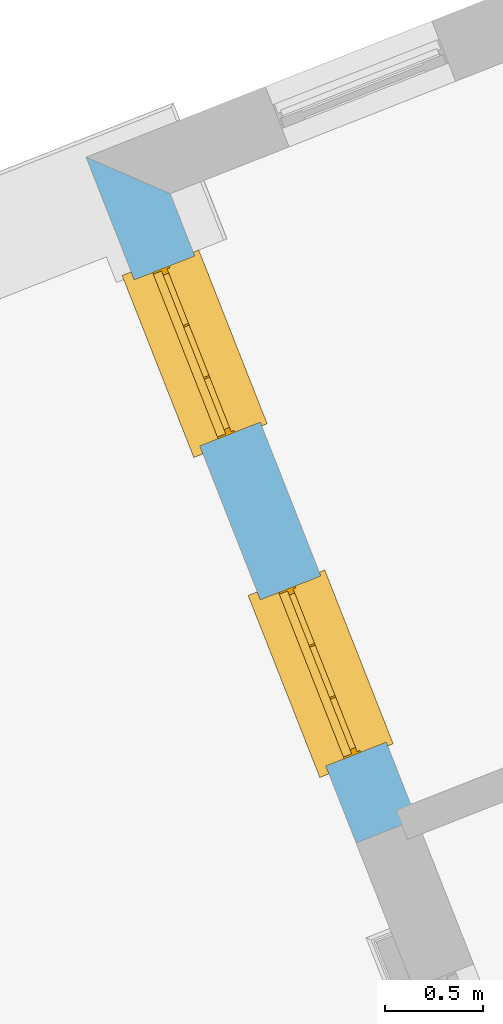
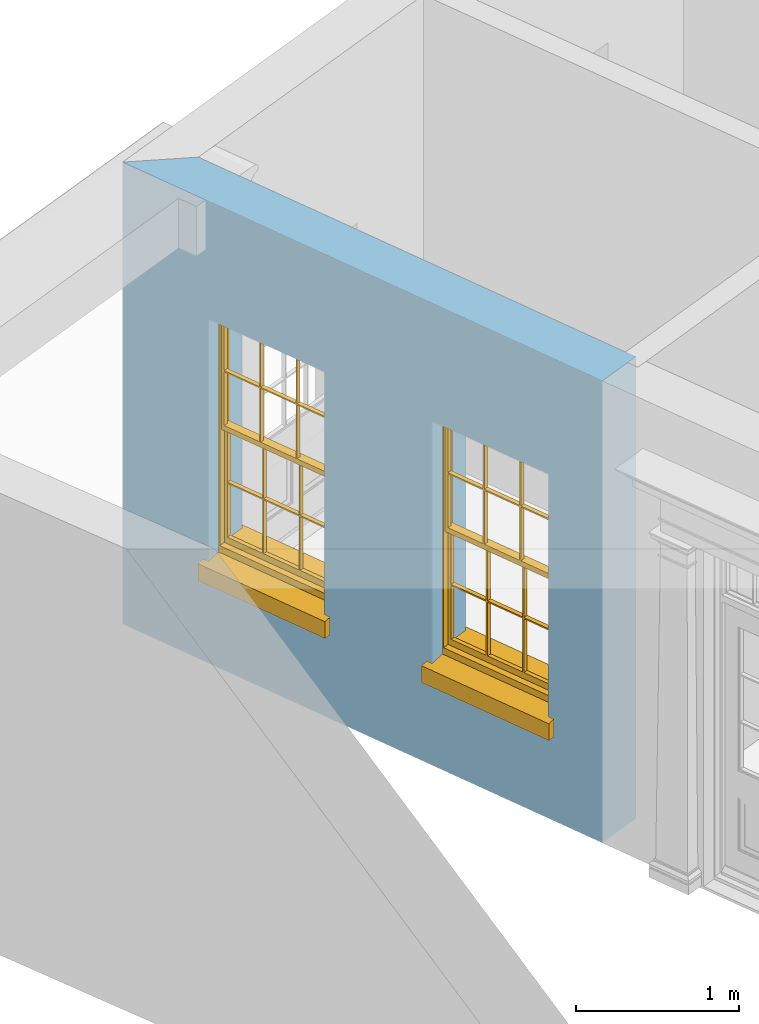
# One storey, part 3 of 8: 2 windows, 2 openings, plus 1 element that does not belong to this part.
"""IFC2X3 building model written with IfcOpenShell, lengths in metres."""

from ifc_helpers import new_model, si_unit, frame, origin, place, context, subcontext, project, spatial, polyline, outline, extrude, faceted_brep, material, layer, layer_set, layer_usage, element, fill, save


model = new_model("IFC2X3")

# Units and contexts
model_context = context("Model", 3, world=origin())
body_context = subcontext(model_context, "Body", "Model", "MODEL_VIEW")
ifc_project = project(units=[si_unit("PLANEANGLEUNIT", "RADIAN"), si_unit("MASSUNIT", "GRAM", prefix="KILO"), si_unit("FORCEUNIT", "NEWTON", prefix="KILO"), si_unit("LENGTHUNIT", "METRE")], contexts=[model_context])

# Site, building, storey
site_placement = place(None, origin())
site = spatial("IfcSite", under=ifc_project, at=site_placement, CompositionType="ELEMENT")
building_placement = place(None, origin())
building = spatial("IfcBuilding", under=site, at=building_placement, Name="Building plot-4", CompositionType="ELEMENT")
storey_placement = place(None, frame((0.0, 0.0, 3.0)))
storey = spatial("IfcBuildingStorey", under=building, at=storey_placement, Name="Floor 0", CompositionType="ELEMENT", Elevation=3.0)

# Wall, openings, windows
ifc_material = material(Name="Masonry")
ifc_layer = layer(ifc_material, 0.33, ventilated=False)
ifc_layer_set = layer_set([ifc_layer], Name="My Wall")
ifc_layer_usage = layer_usage(ifc_layer_set, "AXIS2", "NEGATIVE", 0.08)
wall_placement = place(storey_placement, origin())
wall = element("IfcWallStandardCase", 1, at=wall_placement, inside=storey, material=ifc_layer_usage, Name="exterior", context=body_context, shape_type="SweptSolid", body=[
    extrude(outline(polyline([(47.5268442142849, 51.9971616921577), (47.0988755747214, 52.1832875730829), (48.4726663727611, 48.69491601247), (48.7797136330055, 48.8158373917891), (47.5268442142849, 51.9971616921577)])), origin(), (0.0, 0.0, 1.0), 3.45),
])
opening_1_placement = place(storey_placement, frame((0.0, 0.0, 0.75)))
opening_1 = element("IfcOpeningElement", 2, at=opening_1_placement, cuts=wall, Name="Opening", ObjectType="Opening", context=body_context, shape_type="SweptSolid", body=[
    extrude(outline(polyline([(47.3443036712984, 51.5600890529762), (47.6777535354815, 50.7133829716963), (47.9848007957258, 50.8343043510155), (47.6513509315428, 51.6810104322953), (47.3443036712984, 51.5600890529762)])), origin(), (0.0, 0.0, 1.0), 1.82),
])
opening_2_placement = place(storey_placement, frame((0.0, 0.0, 0.75)))
opening_2 = element("IfcOpeningElement", 3, at=opening_2_placement, cuts=wall, Name="Opening", ObjectType="Opening", context=body_context, shape_type="SweptSolid", body=[
    extrude(outline(polyline([(47.9853955175459, 49.9322090530653), (48.3188453817289, 49.0855029717855), (48.6258926419733, 49.2064243511046), (48.2924427777902, 50.0531304323845), (47.9853955175459, 49.9322090530653)])), origin(), (0.0, 0.0, 1.0), 1.82),
])
window_1_placement = place(storey_placement, frame((47.5769152320896, 51.651696158521, 0.75), z_axis=(0.0, 0.0, 1.0), x_axis=(0.333449864183095, -0.846706081279848, 0.0)))
window_1 = element("IfcWindow", 4, at=window_1_placement, inside=storey, Name="toilet outside window", OverallHeight=1.82, OverallWidth=0.91, context=body_context, shape_type="Brep", held_by="IfcProductRepresentation", body=[
    faceted_brep([(0.033125, -0.105, 0.975209), (0.01, -0.105, 0.975209), (0.033125, -0.105, 1.376042), (0.876875, -0.105, 0.975209), (0.876875, -0.105, 1.376042), (0.9, -0.105, 0.975209), (0.876875, -0.105, 1.386042), (0.876875, -0.105, 1.786875), (0.9, -0.105, 1.81), (0.033125, -0.105, 1.786875), (0.033125, -0.105, 1.386042), (0.01, -0.105, 1.81), (0.876875, -0.135, 1.376042), (0.876875, -0.135, 0.975209), (0.9, -0.135, 0.937083), (0.033125, -0.135, 1.786875), (0.01, -0.135, 1.81), (0.033125, -0.135, 1.386042), (0.01, -0.135, 0.937083), (0.033125, -0.135, 0.975209), (0.033125, -0.135, 1.376042), (0.876875, -0.135, 1.786875), (0.876875, -0.135, 1.386042), (0.9, -0.135, 1.81), (0.033125, -0.105, 0.937083), (0.01, -0.105, 0.937083), (0.033125, -0.105, 0.53625), (0.876875, -0.105, 0.937083), (0.876875, -0.105, 0.53625), (0.9, -0.105, 0.937083), (0.876875, -0.105, 0.52625), (0.876875, -0.105, 0.125417), (0.9, -0.105, 0.077167), (0.033125, -0.105, 0.125417), (0.033125, -0.105, 0.52625), (0.01, -0.105, 0.077167), (-0.0425, -0.25, 0.01), (-0.0425, -0.3, 0.001667), (0.0, -0.25, 0.01), (0.9525, -0.25, 0.01), (0.91, -0.25, 0.01), (0.9525, -0.3, 0.001667), (-0.02, 0.08, 0.077167), (0.0, 0.08, 0.077167), (-0.02, 0.11, 0.077167), (0.0, -0.06, 0.077167), (0.01, -0.06, 0.077167), (0.91, -0.06, 0.077167), (0.91, 0.08, 0.077167), (0.9, -0.06, 0.077167), (0.93, 0.08, 0.077167), (0.93, 0.11, 0.077167), (0.01, -0.075, 0.975209), (0.9, -0.075, 0.975209), (0.876875, -0.075, 0.125417), (0.876875, -0.075, 0.52625), (0.9, -0.075, 0.077167), (0.876875, -0.075, 0.53625), (0.876875, -0.075, 0.937083), (0.033125, -0.075, 0.125417), (0.01, -0.075, 0.077167), (0.033125, -0.075, 0.52625), (0.033125, -0.075, 0.937083), (0.033125, -0.075, 0.53625), (-0.02, 0.08, 0.052167), (-0.02, 0.11, 0.052167), (0.93, 0.11, 0.052167), (0.93, 0.08, 0.052167), (0.91, 0.08, 0.052167), (0.0, 0.08, 0.052167), (0.91, -0.15, 0.026667), (0.0, -0.15, 0.026667), (-0.0425, -0.3, -0.123333), (0.9525, -0.3, -0.123333), (-0.0425, -0.25, -0.123333), (0.9525, -0.25, -0.123333), (0.01, -0.06, 1.81), (0.9, -0.06, 1.81), (0.0, -0.06, 1.82), (0.91, -0.06, 1.82), (0.01, -0.15, 0.077167), (0.9, -0.15, 0.077167), (0.592292, -0.105, 0.125417), (0.592292, -0.075, 0.125417), (0.317708, -0.075, 0.125417), (0.317708, -0.105, 0.125417), (0.592292, -0.105, 0.53625), (0.317708, -0.105, 0.53625), (0.317708, -0.105, 0.52625), (0.592292, -0.105, 0.52625), (0.592292, -0.075, 0.53625), (0.317708, -0.075, 0.53625), (0.592292, -0.135, 1.386042), (0.592292, -0.105, 1.386042), (0.317708, -0.105, 1.386042), (0.317708, -0.135, 1.386042), (0.317708, -0.135, 1.376042), (0.592292, -0.135, 1.376042), (0.317708, -0.105, 1.376042), (0.592292, -0.105, 1.376042), (0.602292, -0.135, 1.376042), (0.592292, -0.135, 0.975209), (0.602292, -0.135, 0.975209), (0.602292, -0.105, 0.975209), (0.592292, -0.105, 0.975209), (0.602292, -0.105, 1.376042), (0.602292, -0.075, 0.53625), (0.602292, -0.105, 0.53625), (0.317708, -0.075, 0.52625), (0.307708, -0.075, 0.125417), (0.307708, -0.075, 0.52625), (0.602292, -0.075, 0.52625), (0.602292, -0.075, 0.125417), (0.592292, -0.075, 0.52625), (0.307708, -0.075, 0.53625), (0.317708, -0.075, 0.937083), (0.307708, -0.075, 0.937083), (0.602292, -0.075, 0.937083), (0.592292, -0.075, 0.937083), (0.307708, -0.105, 0.52625), (0.307708, -0.105, 0.125417), (0.307708, -0.105, 0.53625), (0.307708, -0.105, 0.937083), (0.592292, -0.105, 0.937083), (0.317708, -0.105, 0.937083), (0.602292, -0.105, 0.937083), (0.602292, -0.105, 0.52625), (0.602292, -0.105, 0.125417), (0.307708, -0.135, 1.386042), (0.307708, -0.135, 1.376042), (0.307708, -0.135, 0.975209), (0.317708, -0.135, 0.975209), (0.317708, -0.135, 1.786875), (0.307708, -0.135, 1.786875), (0.602292, -0.135, 1.786875), (0.592292, -0.135, 1.786875), (0.602292, -0.135, 1.386042), (0.602292, -0.105, 1.386042), (0.307708, -0.105, 1.386042), (0.307708, -0.105, 1.786875), (0.317708, -0.105, 1.786875), (0.592292, -0.105, 1.786875), (0.602292, -0.105, 1.786875), (0.307708, -0.105, 1.376042), (0.317708, -0.105, 0.975209), (0.307708, -0.105, 0.975209), (0.91, -0.15, 1.82), (0.9, -0.15, 1.81), (0.01, -0.15, 1.81), (0.0, -0.15, 1.82), (0.91, -0.25, 0.0), (0.0, -0.25, 0.0), (0.91, 0.08, 0.0), (0.0, 0.08, 0.0)], [[[0, 1, 2]], [[3, 4, 5]], [[6, 7, 8]], [[9, 10, 11]], [[12, 13, 14]], [[15, 16, 17]], [[18, 19, 20]], [[21, 22, 23]], [[24, 25, 26]], [[27, 28, 29]], [[30, 31, 32]], [[33, 34, 35]], [[14, 27, 29]], [[25, 24, 18]], [[36, 37, 38]], [[39, 40, 41]], [[42, 43, 44]], [[45, 46, 43]], [[47, 48, 49]], [[50, 51, 48]], [[1, 0, 52]], [[5, 53, 3]], [[54, 55, 56]], [[57, 58, 53]], [[59, 60, 61]], [[62, 63, 52]], [[48, 43, 46, 49]], [[51, 44, 43, 48]], [[64, 42, 44, 65]], [[65, 44, 51, 66]], [[66, 51, 50, 67]], [[65, 66, 68, 69]], [[60, 56, 49, 46]], [[70, 71, 38, 40]], [[37, 41, 40, 38]], [[37, 72, 73, 41]], [[74, 75, 73, 72]], [[8, 11, 76, 77]], [[76, 78, 79, 77]], [[32, 35, 80, 81]], [[81, 80, 71, 70]], [[82, 83, 84, 85]], [[86, 87, 88, 89]], [[86, 90, 91, 87]], [[92, 93, 94, 95]], [[92, 95, 96, 97]], [[96, 98, 99, 97]], [[100, 97, 101, 102]], [[103, 104, 99, 105]], [[97, 99, 104, 101]], [[102, 103, 105, 100]], [[28, 57, 106, 107]], [[108, 84, 109, 110]], [[111, 112, 83, 113]], [[114, 110, 61, 63]], [[90, 113, 108, 91]], [[115, 91, 114, 116]], [[117, 106, 90, 118]], [[111, 106, 57, 55]], [[119, 110, 109, 120]], [[34, 61, 110, 119]], [[89, 113, 83, 82]], [[88, 108, 113, 89]], [[85, 84, 108, 88]], [[121, 114, 63, 26]], [[122, 116, 114, 121]], [[123, 118, 90, 86]], [[87, 91, 115, 124]], [[107, 106, 117, 125]], [[126, 111, 55, 30]], [[127, 112, 111, 126]], [[126, 30, 28, 107]], [[88, 119, 120, 85]], [[126, 89, 82, 127]], [[125, 123, 86, 107]], [[121, 26, 34, 119]], [[124, 122, 121, 87]], [[128, 17, 20, 129]], [[96, 129, 130, 131]], [[132, 133, 128, 95]], [[134, 135, 92, 136]], [[100, 12, 22, 136]], [[137, 6, 4, 105]], [[94, 138, 139, 140]], [[137, 93, 141, 142]], [[99, 98, 94, 93]], [[143, 2, 10, 138]], [[144, 145, 143, 98]], [[129, 143, 145, 130]], [[20, 2, 143, 129]], [[131, 144, 98, 96]], [[128, 138, 10, 17]], [[133, 139, 138, 128]], [[135, 141, 93, 92]], [[95, 94, 140, 132]], [[22, 6, 137, 136]], [[136, 137, 142, 134]], [[100, 105, 4, 12]], [[107, 86, 89, 126]], [[106, 111, 113, 90]], [[91, 108, 110, 114]], [[87, 121, 119, 88]], [[97, 100, 136, 92]], [[129, 96, 95, 128]], [[98, 143, 138, 94]], [[105, 99, 93, 137]], [[131, 101, 104, 144]], [[124, 115, 118, 123]], [[132, 140, 141, 135]], [[120, 109, 59, 33]], [[15, 9, 139, 133]], [[134, 142, 7, 21]], [[31, 54, 112, 127]], [[36, 74, 72, 37]], [[39, 41, 73, 75]], [[18, 14, 101, 131]], [[23, 16, 132, 135]], [[83, 56, 60, 84]], [[52, 53, 118, 115]], [[53, 52, 144, 104]], [[11, 8, 141, 140]], [[14, 18, 124, 123]], [[2, 1, 11, 10]], [[8, 5, 4, 6]], [[57, 53, 56, 55]], [[60, 52, 63, 61]], [[26, 25, 35, 34]], [[32, 29, 28, 30]], [[14, 23, 22, 12]], [[18, 20, 17, 16]], [[19, 0, 2, 20]], [[17, 10, 9, 15]], [[12, 4, 3, 13]], [[21, 7, 6, 22]], [[27, 58, 57, 28]], [[30, 55, 54, 31]], [[33, 59, 61, 34]], [[26, 63, 62, 24]], [[5, 8, 77, 53]], [[76, 11, 1, 52]], [[46, 45, 78, 76]], [[49, 77, 79, 47]], [[70, 146, 147, 81]], [[71, 80, 148, 149]], [[19, 130, 145, 0]], [[102, 13, 3, 103]], [[116, 122, 24, 62]], [[29, 32, 81, 14]], [[80, 35, 25, 18]], [[60, 46, 76, 52]], [[77, 49, 56, 53]], [[23, 14, 81, 147]], [[16, 148, 80, 18]], [[35, 85, 120]], [[120, 33, 35]], [[127, 82, 32]], [[32, 31, 127]], [[32, 82, 85, 35]], [[102, 101, 14]], [[14, 13, 102]], [[18, 131, 130]], [[130, 19, 18]], [[134, 21, 23]], [[23, 135, 134]], [[16, 15, 133]], [[133, 132, 16]], [[11, 140, 139]], [[139, 9, 11]], [[142, 141, 8]], [[8, 7, 142]], [[23, 147, 148, 16]], [[146, 149, 148, 147]], [[52, 115, 116]], [[116, 62, 52]], [[118, 53, 117]], [[58, 117, 53]], [[27, 125, 117, 58]], [[56, 83, 112]], [[112, 54, 56]], [[109, 84, 60]], [[60, 59, 109]], [[125, 27, 14]], [[14, 123, 125]], [[122, 124, 18]], [[18, 24, 122]], [[145, 144, 52]], [[52, 0, 145]], [[103, 3, 53]], [[53, 104, 103]], [[79, 78, 149, 146]], [[78, 45, 71, 149]], [[146, 70, 47, 79]], [[150, 75, 74, 151]], [[68, 66, 67]], [[48, 68, 67, 50]], [[69, 64, 65]], [[42, 64, 69, 43]], [[69, 68, 152, 153]], [[70, 68, 48, 47]], [[150, 152, 68, 70]], [[43, 69, 71, 45]], [[69, 153, 151, 71]], [[152, 150, 151, 153]], [[38, 151, 74, 36]], [[71, 151, 38]], [[39, 75, 150, 40]], [[40, 150, 70]]]),
])
fill(opening_1, window_1)
window_2_placement = place(storey_placement, frame((48.218007078337, 50.0238161586101, 0.75), z_axis=(0.0, 0.0, 1.0), x_axis=(0.333449864183088, -0.846706081279848, 0.0)))
window_2 = element("IfcWindow", 5, at=window_2_placement, inside=storey, Name="toilet outside window", OverallHeight=1.82, OverallWidth=0.91, context=body_context, shape_type="Brep", held_by="IfcProductRepresentation", body=[
    faceted_brep([(0.033125, -0.105, 0.975209), (0.01, -0.105, 0.975209), (0.033125, -0.105, 1.376042), (0.876875, -0.105, 0.975209), (0.876875, -0.105, 1.376042), (0.9, -0.105, 0.975209), (0.876875, -0.105, 1.386042), (0.876875, -0.105, 1.786875), (0.9, -0.105, 1.81), (0.033125, -0.105, 1.786875), (0.033125, -0.105, 1.386042), (0.01, -0.105, 1.81), (0.876875, -0.135, 1.376042), (0.876875, -0.135, 0.975209), (0.9, -0.135, 0.937083), (0.033125, -0.135, 1.786875), (0.01, -0.135, 1.81), (0.033125, -0.135, 1.386042), (0.01, -0.135, 0.937083), (0.033125, -0.135, 0.975209), (0.033125, -0.135, 1.376042), (0.876875, -0.135, 1.786875), (0.876875, -0.135, 1.386042), (0.9, -0.135, 1.81), (0.033125, -0.105, 0.937083), (0.01, -0.105, 0.937083), (0.033125, -0.105, 0.53625), (0.876875, -0.105, 0.937083), (0.876875, -0.105, 0.53625), (0.9, -0.105, 0.937083), (0.876875, -0.105, 0.52625), (0.876875, -0.105, 0.125417), (0.9, -0.105, 0.077167), (0.033125, -0.105, 0.125417), (0.033125, -0.105, 0.52625), (0.01, -0.105, 0.077167), (-0.0425, -0.25, 0.01), (-0.0425, -0.3, 0.001667), (0.0, -0.25, 0.01), (0.9525, -0.25, 0.01), (0.91, -0.25, 0.01), (0.9525, -0.3, 0.001667), (-0.02, 0.08, 0.077167), (0.0, 0.08, 0.077167), (-0.02, 0.11, 0.077167), (0.0, -0.06, 0.077167), (0.01, -0.06, 0.077167), (0.91, -0.06, 0.077167), (0.91, 0.08, 0.077167), (0.9, -0.06, 0.077167), (0.93, 0.08, 0.077167), (0.93, 0.11, 0.077167), (0.01, -0.075, 0.975209), (0.9, -0.075, 0.975209), (0.876875, -0.075, 0.125417), (0.876875, -0.075, 0.52625), (0.9, -0.075, 0.077167), (0.876875, -0.075, 0.53625), (0.876875, -0.075, 0.937083), (0.033125, -0.075, 0.125417), (0.01, -0.075, 0.077167), (0.033125, -0.075, 0.52625), (0.033125, -0.075, 0.937083), (0.033125, -0.075, 0.53625), (-0.02, 0.08, 0.052167), (-0.02, 0.11, 0.052167), (0.93, 0.11, 0.052167), (0.93, 0.08, 0.052167), (0.91, 0.08, 0.052167), (0.0, 0.08, 0.052167), (0.91, -0.15, 0.026667), (0.0, -0.15, 0.026667), (-0.0425, -0.3, -0.123333), (0.9525, -0.3, -0.123333), (-0.0425, -0.25, -0.123333), (0.9525, -0.25, -0.123333), (0.01, -0.06, 1.81), (0.9, -0.06, 1.81), (0.0, -0.06, 1.82), (0.91, -0.06, 1.82), (0.01, -0.15, 0.077167), (0.9, -0.15, 0.077167), (0.592292, -0.105, 0.125417), (0.592292, -0.075, 0.125417), (0.317708, -0.075, 0.125417), (0.317708, -0.105, 0.125417), (0.592292, -0.105, 0.53625), (0.317708, -0.105, 0.53625), (0.317708, -0.105, 0.52625), (0.592292, -0.105, 0.52625), (0.592292, -0.075, 0.53625), (0.317708, -0.075, 0.53625), (0.592292, -0.135, 1.386042), (0.592292, -0.105, 1.386042), (0.317708, -0.105, 1.386042), (0.317708, -0.135, 1.386042), (0.317708, -0.135, 1.376042), (0.592292, -0.135, 1.376042), (0.317708, -0.105, 1.376042), (0.592292, -0.105, 1.376042), (0.602292, -0.135, 1.376042), (0.592292, -0.135, 0.975209), (0.602292, -0.135, 0.975209), (0.602292, -0.105, 0.975209), (0.592292, -0.105, 0.975209), (0.602292, -0.105, 1.376042), (0.602292, -0.075, 0.53625), (0.602292, -0.105, 0.53625), (0.317708, -0.075, 0.52625), (0.307708, -0.075, 0.125417), (0.307708, -0.075, 0.52625), (0.602292, -0.075, 0.52625), (0.602292, -0.075, 0.125417), (0.592292, -0.075, 0.52625), (0.307708, -0.075, 0.53625), (0.317708, -0.075, 0.937083), (0.307708, -0.075, 0.937083), (0.602292, -0.075, 0.937083), (0.592292, -0.075, 0.937083), (0.307708, -0.105, 0.52625), (0.307708, -0.105, 0.125417), (0.307708, -0.105, 0.53625), (0.307708, -0.105, 0.937083), (0.592292, -0.105, 0.937083), (0.317708, -0.105, 0.937083), (0.602292, -0.105, 0.937083), (0.602292, -0.105, 0.52625), (0.602292, -0.105, 0.125417), (0.307708, -0.135, 1.386042), (0.307708, -0.135, 1.376042), (0.307708, -0.135, 0.975209), (0.317708, -0.135, 0.975209), (0.317708, -0.135, 1.786875), (0.307708, -0.135, 1.786875), (0.602292, -0.135, 1.786875), (0.592292, -0.135, 1.786875), (0.602292, -0.135, 1.386042), (0.602292, -0.105, 1.386042), (0.307708, -0.105, 1.386042), (0.307708, -0.105, 1.786875), (0.317708, -0.105, 1.786875), (0.592292, -0.105, 1.786875), (0.602292, -0.105, 1.786875), (0.307708, -0.105, 1.376042), (0.317708, -0.105, 0.975209), (0.307708, -0.105, 0.975209), (0.91, -0.15, 1.82), (0.9, -0.15, 1.81), (0.01, -0.15, 1.81), (0.0, -0.15, 1.82), (0.91, -0.25, 0.0), (0.0, -0.25, 0.0), (0.91, 0.08, 0.0), (0.0, 0.08, 0.0)], [[[0, 1, 2]], [[3, 4, 5]], [[6, 7, 8]], [[9, 10, 11]], [[12, 13, 14]], [[15, 16, 17]], [[18, 19, 20]], [[21, 22, 23]], [[24, 25, 26]], [[27, 28, 29]], [[30, 31, 32]], [[33, 34, 35]], [[14, 27, 29]], [[25, 24, 18]], [[36, 37, 38]], [[39, 40, 41]], [[42, 43, 44]], [[45, 46, 43]], [[47, 48, 49]], [[50, 51, 48]], [[1, 0, 52]], [[5, 53, 3]], [[54, 55, 56]], [[57, 58, 53]], [[59, 60, 61]], [[62, 63, 52]], [[48, 43, 46, 49]], [[51, 44, 43, 48]], [[64, 42, 44, 65]], [[65, 44, 51, 66]], [[66, 51, 50, 67]], [[65, 66, 68, 69]], [[60, 56, 49, 46]], [[70, 71, 38, 40]], [[37, 41, 40, 38]], [[37, 72, 73, 41]], [[74, 75, 73, 72]], [[8, 11, 76, 77]], [[76, 78, 79, 77]], [[32, 35, 80, 81]], [[81, 80, 71, 70]], [[82, 83, 84, 85]], [[86, 87, 88, 89]], [[86, 90, 91, 87]], [[92, 93, 94, 95]], [[92, 95, 96, 97]], [[96, 98, 99, 97]], [[100, 97, 101, 102]], [[103, 104, 99, 105]], [[97, 99, 104, 101]], [[102, 103, 105, 100]], [[28, 57, 106, 107]], [[108, 84, 109, 110]], [[111, 112, 83, 113]], [[114, 110, 61, 63]], [[90, 113, 108, 91]], [[115, 91, 114, 116]], [[117, 106, 90, 118]], [[111, 106, 57, 55]], [[119, 110, 109, 120]], [[34, 61, 110, 119]], [[89, 113, 83, 82]], [[88, 108, 113, 89]], [[85, 84, 108, 88]], [[121, 114, 63, 26]], [[122, 116, 114, 121]], [[123, 118, 90, 86]], [[87, 91, 115, 124]], [[107, 106, 117, 125]], [[126, 111, 55, 30]], [[127, 112, 111, 126]], [[126, 30, 28, 107]], [[88, 119, 120, 85]], [[126, 89, 82, 127]], [[125, 123, 86, 107]], [[121, 26, 34, 119]], [[124, 122, 121, 87]], [[128, 17, 20, 129]], [[96, 129, 130, 131]], [[132, 133, 128, 95]], [[134, 135, 92, 136]], [[100, 12, 22, 136]], [[137, 6, 4, 105]], [[94, 138, 139, 140]], [[137, 93, 141, 142]], [[99, 98, 94, 93]], [[143, 2, 10, 138]], [[144, 145, 143, 98]], [[129, 143, 145, 130]], [[20, 2, 143, 129]], [[131, 144, 98, 96]], [[128, 138, 10, 17]], [[133, 139, 138, 128]], [[135, 141, 93, 92]], [[95, 94, 140, 132]], [[22, 6, 137, 136]], [[136, 137, 142, 134]], [[100, 105, 4, 12]], [[107, 86, 89, 126]], [[106, 111, 113, 90]], [[91, 108, 110, 114]], [[87, 121, 119, 88]], [[97, 100, 136, 92]], [[129, 96, 95, 128]], [[98, 143, 138, 94]], [[105, 99, 93, 137]], [[131, 101, 104, 144]], [[124, 115, 118, 123]], [[132, 140, 141, 135]], [[120, 109, 59, 33]], [[15, 9, 139, 133]], [[134, 142, 7, 21]], [[31, 54, 112, 127]], [[36, 74, 72, 37]], [[39, 41, 73, 75]], [[18, 14, 101, 131]], [[23, 16, 132, 135]], [[83, 56, 60, 84]], [[52, 53, 118, 115]], [[53, 52, 144, 104]], [[11, 8, 141, 140]], [[14, 18, 124, 123]], [[2, 1, 11, 10]], [[8, 5, 4, 6]], [[57, 53, 56, 55]], [[60, 52, 63, 61]], [[26, 25, 35, 34]], [[32, 29, 28, 30]], [[14, 23, 22, 12]], [[18, 20, 17, 16]], [[19, 0, 2, 20]], [[17, 10, 9, 15]], [[12, 4, 3, 13]], [[21, 7, 6, 22]], [[27, 58, 57, 28]], [[30, 55, 54, 31]], [[33, 59, 61, 34]], [[26, 63, 62, 24]], [[5, 8, 77, 53]], [[76, 11, 1, 52]], [[46, 45, 78, 76]], [[49, 77, 79, 47]], [[70, 146, 147, 81]], [[71, 80, 148, 149]], [[19, 130, 145, 0]], [[102, 13, 3, 103]], [[116, 122, 24, 62]], [[29, 32, 81, 14]], [[80, 35, 25, 18]], [[60, 46, 76, 52]], [[77, 49, 56, 53]], [[23, 14, 81, 147]], [[16, 148, 80, 18]], [[35, 85, 120]], [[120, 33, 35]], [[127, 82, 32]], [[32, 31, 127]], [[32, 82, 85, 35]], [[102, 101, 14]], [[14, 13, 102]], [[18, 131, 130]], [[130, 19, 18]], [[134, 21, 23]], [[23, 135, 134]], [[16, 15, 133]], [[133, 132, 16]], [[11, 140, 139]], [[139, 9, 11]], [[142, 141, 8]], [[8, 7, 142]], [[23, 147, 148, 16]], [[146, 149, 148, 147]], [[52, 115, 116]], [[116, 62, 52]], [[118, 53, 117]], [[58, 117, 53]], [[27, 125, 117, 58]], [[56, 83, 112]], [[112, 54, 56]], [[109, 84, 60]], [[60, 59, 109]], [[125, 27, 14]], [[14, 123, 125]], [[122, 124, 18]], [[18, 24, 122]], [[145, 144, 52]], [[52, 0, 145]], [[103, 3, 53]], [[53, 104, 103]], [[79, 78, 149, 146]], [[78, 45, 71, 149]], [[146, 70, 47, 79]], [[150, 75, 74, 151]], [[68, 66, 67]], [[48, 68, 67, 50]], [[69, 64, 65]], [[42, 64, 69, 43]], [[69, 68, 152, 153]], [[70, 68, 48, 47]], [[150, 152, 68, 70]], [[43, 69, 71, 45]], [[69, 153, 151, 71]], [[152, 150, 151, 153]], [[38, 151, 74, 36]], [[71, 151, 38]], [[39, 75, 150, 40]], [[40, 150, 70]]]),
])
fill(opening_2, window_2)

save(model, "model.ifc")
